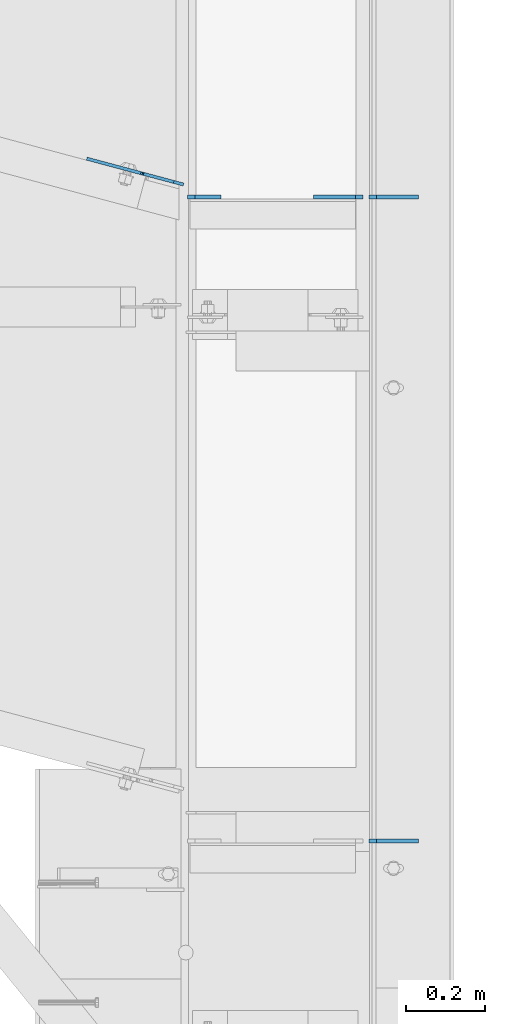
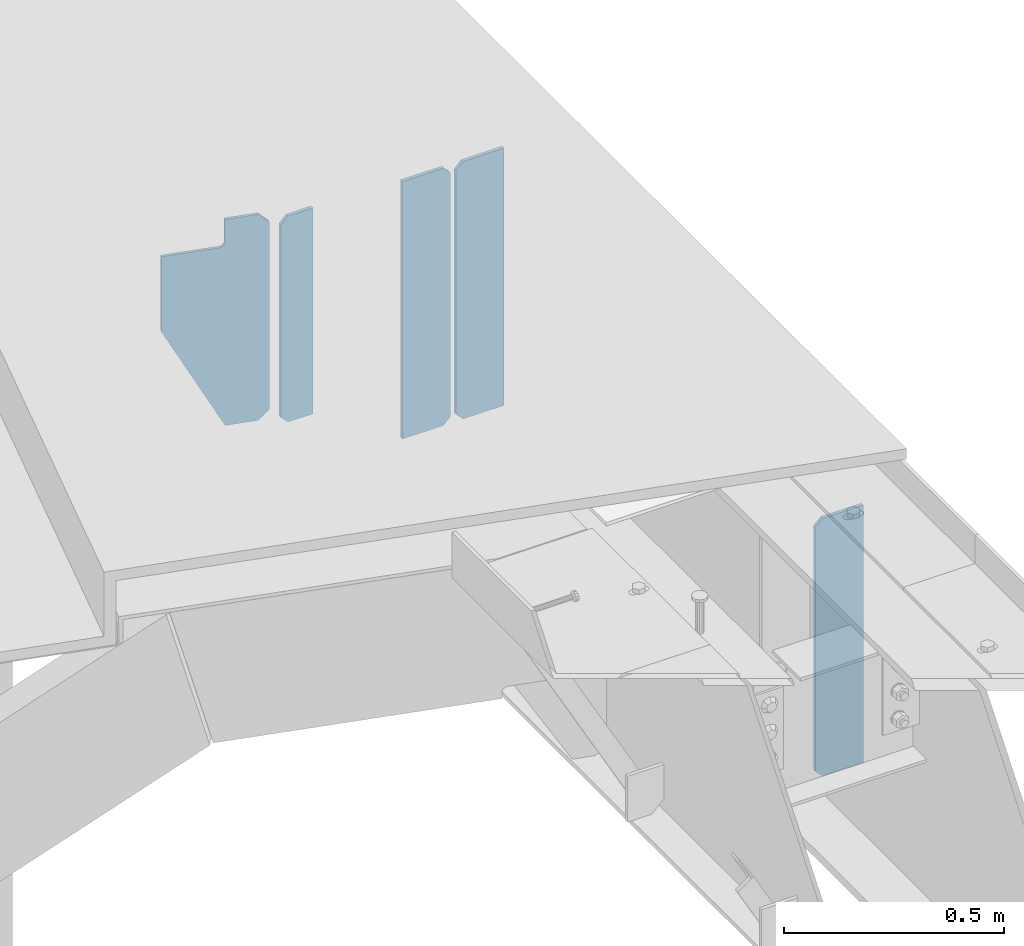
# One storey, part 1686 of 1763: 5 plates, 2 elements without a shape of their own.
"""IFC2X3 building model written with IfcOpenShell, lengths in millimetres."""

from ifc_helpers import new_model, si_unit, frame, origin_with_axes, place, context, subcontext, project, spatial, faceted_brep, material, type_object, element, aggregate, save


model = new_model("IFC2X3")

# Units and contexts
model_context = context("Model", 3, precision=1e-05, world=origin_with_axes())
body_context = subcontext(model_context, "Body", "Model", "MODEL_VIEW")
ifc_project = project(units=[si_unit("LENGTHUNIT", "METRE", prefix="MILLI"), si_unit("AREAUNIT", "SQUARE_METRE"), si_unit("VOLUMEUNIT", "CUBIC_METRE"), si_unit("MASSUNIT", "GRAM", prefix="KILO"), si_unit("TIMEUNIT", "SECOND"), si_unit("PLANEANGLEUNIT", "RADIAN"), si_unit("SOLIDANGLEUNIT", "STERADIAN"), si_unit("THERMODYNAMICTEMPERATUREUNIT", "DEGREE_CELSIUS"), si_unit("LUMINOUSINTENSITYUNIT", "LUMEN")], contexts=[model_context])

# Site, building, storey
site_placement = place(None, origin_with_axes())
site = spatial("IfcSite", under=ifc_project, at=site_placement, CompositionType="ELEMENT")
building_placement = place(site_placement, origin_with_axes())
building = spatial("IfcBuilding", under=site, at=building_placement, Name="Undefined", CompositionType="ELEMENT")
storey_placement = place(building_placement, origin_with_axes())
storey = spatial("IfcBuildingStorey", under=building, at=storey_placement, Name="Undefined", CompositionType="ELEMENT", Elevation=0.0)

# Assembly, plates
assembly_1_placement = place(storey_placement, origin_with_axes())
assembly_1 = element("IfcElementAssembly", 1, at=assembly_1_placement, inside=storey, Name="BEAM", AssemblyPlace="NOTDEFINED", PredefinedType="RIGID_FRAME")
ifc_material = material(Name="STEEL/A36")
plate_type_1 = type_object("IfcPlateType", PredefinedType="NOTDEFINED")
plate_1_placement = place(assembly_1_placement, frame((-21073.1396174484, 58567.366503532, 4456.1125), z_axis=(0.0, 0.0, 1.0), x_axis=(-1.0, 0.0, 0.0)))
plate_1 = element("IfcPlate", 2, at=plate_1_placement, type_object=plate_type_1, material=ifc_material, Name="PLATE", context=body_context, shape_type="Brep", body=[
    faceted_brep([(0.0, -4.76249999999982, 0.0), (0.0, -4.76249999999709, 714.375), (0.0, 4.76249999999709, 714.375), (0.0, 4.76249999999982, 0.0), (107.156253814697, -4.76249999999709, 714.375), (107.156253814697, 4.76249999999709, 714.375), (126.206253051758, -4.76249999999709, 695.325000762939), (126.206253051758, 4.76249999999709, 695.325000762939), (126.206253051758, -4.76249999999709, 19.0499992370605), (126.206253051758, 4.76249999999709, 19.0499992370605), (107.156253814697, -4.76249999999709, 0.0), (107.156253814697, 4.76249999999709, 0.0)], [[[0, 1, 2, 3]], [[1, 4, 5, 2]], [[4, 6, 7, 5]], [[6, 8, 9, 7]], [[8, 10, 11, 9]], [[10, 0, 3, 11]], [[5, 7, 9, 11, 3, 2]], [[10, 8, 6, 4, 1, 0]]]),
])
plate_2_placement = place(assembly_1_placement, frame((-21073.1396174484, 60201.0276485763, 4456.1125), z_axis=(0.0, 0.0, 1.0), x_axis=(-1.0, 0.0, 0.0)))
plate_2 = element("IfcPlate", 3, at=plate_2_placement, type_object=plate_type_1, material=ifc_material, Name="PLATE", context=body_context, shape_type="Brep", body=[
    faceted_brep([(0.0, -4.76249999999982, 0.0), (0.0, -4.76249999999709, 714.375), (0.0, 4.76249999999709, 714.375), (0.0, 4.76249999999982, 0.0), (107.156253814697, -4.76249999999709, 714.375), (107.156253814697, 4.76249999999709, 714.375), (126.206253051758, -4.76249999999709, 695.325000762939), (126.206253051758, 4.76249999999709, 695.325000762939), (126.206253051758, -4.76249999999709, 19.0499992370605), (126.206253051758, 4.76249999999709, 19.0499992370605), (107.156253814697, -4.76249999999709, 0.0), (107.156253814697, 4.76249999999709, 0.0)], [[[0, 1, 2, 3]], [[1, 4, 5, 2]], [[4, 6, 7, 5]], [[6, 8, 9, 7]], [[8, 10, 11, 9]], [[10, 0, 3, 11]], [[5, 7, 9, 11, 3, 2]], [[10, 8, 6, 4, 1, 0]]]),
])
plate_3_placement = place(assembly_1_placement, frame((-21213.6333674484, 60201.0276485763, 4456.1125), z_axis=(0.0, 0.0, 1.0), x_axis=(-1.0, 0.0, 0.0)))
plate_3 = element("IfcPlate", 4, at=plate_3_placement, type_object=plate_type_1, material=ifc_material, Name="PLATE", context=body_context, shape_type="Brep", body=[
    faceted_brep([(6.96272763889283e-08, -4.76249999999709, 19.0499992370605), (0.0, -4.76249999999709, 695.325000762939), (0.0, 4.76249999999709, 695.325000762939), (6.96454662829638e-08, 4.76249999999709, 19.0499992370605), (19.0499992370605, -4.76249999999709, 714.375), (19.0499992370605, 4.76249999999709, 714.375), (126.206253051758, -4.76249999999709, 714.375), (126.206253051758, 4.76249999999709, 714.375), (126.206253051758, -4.76249999999709, 0.0), (126.206253051758, 4.76249999999709, 0.0), (19.0499992370533, -4.76249999996799, -2.09183781407773e-11), (19.0499992370678, 4.76250000003347, -2.09183781407773e-11)], [[[0, 1, 2, 3]], [[1, 4, 5, 2]], [[4, 6, 7, 5]], [[6, 8, 9, 7]], [[8, 10, 11, 9]], [[10, 0, 3, 11]], [[5, 7, 9, 11, 3, 2]], [[10, 8, 6, 4, 1, 0]]]),
])
aggregate(assembly_1, [plate_1, plate_2, plate_3])

assembly_2_placement = place(storey_placement, origin_with_axes())
assembly_2 = element("IfcElementAssembly", 5, at=assembly_2_placement, inside=storey, Name="BEAM", AssemblyPlace="NOTDEFINED", PredefinedType="RIGID_FRAME")
plate_type_2 = type_object("IfcPlateType", PredefinedType="NOTDEFINED")
plate_4_placement = place(assembly_2_placement, frame((-21574.7896174484, 60201.0276485763, 4608.5125), z_axis=(0.0, 0.0, 1.0), x_axis=(-1.0, 0.0, 0.0)))
plate_4 = element("IfcPlate", 6, at=plate_4_placement, type_object=plate_type_2, material=ifc_material, Name="PLATE", context=body_context, shape_type="Brep", body=[
    faceted_brep([(0.0, -4.76249999999982, 0.0), (0.0, -4.76249999999709, 571.5), (0.0, 4.76249999999709, 571.5), (0.0, 4.76249999999982, 0.0), (65.0874977111816, -4.76249999999709, 571.5), (65.0874977111816, 4.76249999999709, 571.5), (84.1374969482422, -4.76249999999709, 552.450000762939), (84.1374969482422, 4.76249999999709, 552.450000762939), (84.1374969482422, -4.76249999999709, 19.0499992370605), (84.1374969482422, 4.76249999999709, 19.0499992370605), (65.0874977111816, -4.76249999999709, 0.0), (65.0874977111816, 4.76249999999709, 0.0)], [[[0, 1, 2, 3]], [[1, 4, 5, 2]], [[4, 6, 7, 5]], [[6, 8, 9, 7]], [[8, 10, 11, 9]], [[10, 0, 3, 11]], [[5, 7, 9, 11, 3, 2]], [[10, 8, 6, 4, 1, 0]]]),
])
plate_type_3 = type_object("IfcPlateType", PredefinedType="NOTDEFINED")
plate_5_placement = place(assembly_2_placement, frame((-21669.4795563746, 60232.8427620788, 5180.01249999962), z_axis=(-0.965913267114846, 0.258865912030774, 0.0), x_axis=(0.0, 0.0, -1.0)))
plate_5 = element("IfcPlate", 7, at=plate_5_placement, type_object=plate_type_3, material=ifc_material, Name="PLATE", context=body_context, shape_type="Brep", body=[
    faceted_brep([(571.499998826022, -3.96899999993184, 104.283546676423), (571.5, 3.96900000006281, 104.283546677521), (284.718998012783, 3.96900000015739, 253.908416748032), (284.718998007862, -3.9689999998518, 253.908416748032), (76.1999969482422, -3.96899999983725, 253.908416747996), (76.1999969482422, 3.96900000015739, 253.908416748032), (76.1999969482431, 3.96900000007008, 117.074662287028), (76.1999969482431, -3.96899999992456, 117.074662287028), (75.2332670256556, 3.96900000006281, 112.214582768982), (75.2332670256556, -3.96899999993184, 112.214582768989), (72.4802531251771, 3.96900000007008, 108.094406300828), (72.4802531251771, -3.96899999993184, 108.094406300836), (68.3600766570235, 3.96900000006281, 105.341392400347), (68.3600766570235, -3.96899999993911, 105.341392400354), (63.499997138978, 3.96900000006281, 104.374662477763), (63.499997138978, -3.96899999993911, 104.37466247777), (0.0, 3.96900000006281, 104.374662477763), (0.0, -3.96899999993911, 104.37466247777), (0.0, 3.96900000001187, 25.3999996185303), (0.0, -3.96899999999005, 25.3999996185375), (25.3999996185303, -3.9690000000046, 7.27595761418343e-12), (25.3999996185303, 3.96899999999732, 0.0), (546.10000038147, -3.9690000000046, 7.27595761418343e-12), (546.10000038147, 3.96899999999732, 0.0), (571.5, -3.96899999999005, 25.3999996185375), (571.5, 3.96900000001187, 25.3999996185303)], [[[0, 1, 2, 3]], [[4, 5, 6, 7]], [[7, 6, 8, 9]], [[9, 8, 10, 11]], [[11, 10, 12, 13]], [[13, 12, 14, 15]], [[15, 14, 16, 17]], [[18, 19, 17, 16]], [[20, 19, 18, 21]], [[22, 20, 21, 23]], [[24, 22, 23, 25]], [[4, 7, 9, 11, 13, 15, 17, 19, 20, 22, 24, 0, 3]], [[5, 4, 3, 2]], [[25, 23, 21, 18, 16, 14, 12, 10, 8, 6, 5, 2, 1]], [[24, 25, 1, 0]]]),
])
aggregate(assembly_2, [plate_4, plate_5])

save(model, "model.ifc")
